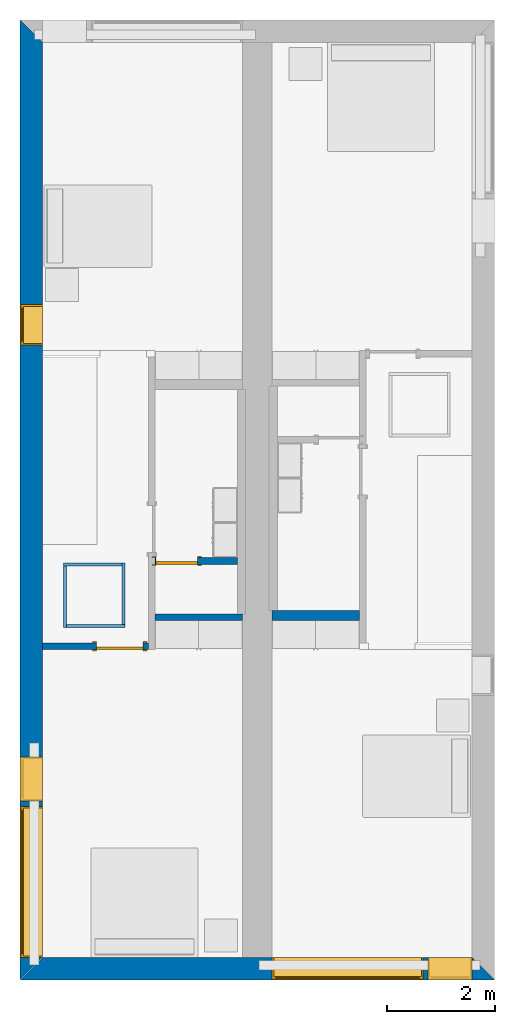
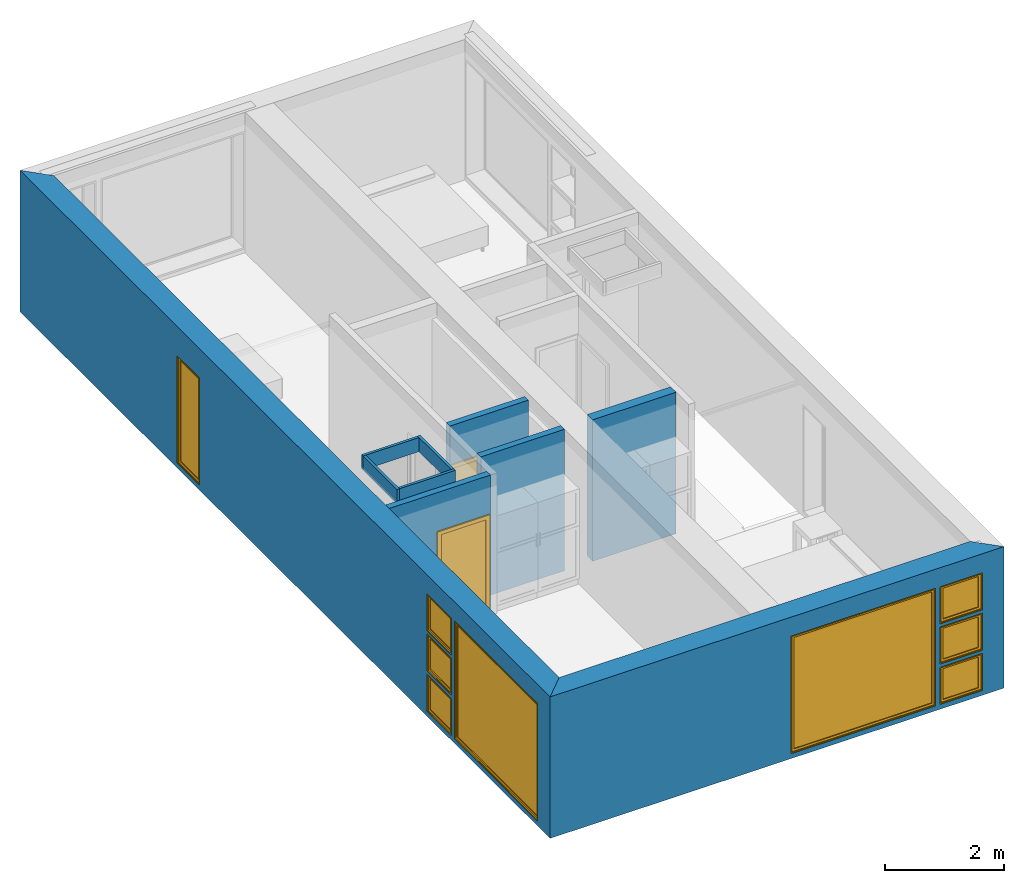
# One storey, part 2 of 14: 10 walls, 9 windows, 2 doors, 11 openings.
"""IFC2X3 building model written with IfcOpenShell, lengths in metres."""

from ifc_helpers import new_model, entity, si_unit, converted_unit, frame, frame_2d, origin, origin_2d_with_axis, place, context, project, spatial, polyline, rectangle, outline, extrude, source, transform, mapped, material, layer, layer_set, layer_usage, type_object, type_shapes, element, fill, save


model = new_model("IFC2X3")

# Units and contexts
model_context = context("Model", 3, precision=1e-09, world=origin())
plan_context = context("Plan", 3, precision=1e-09, world=origin())
ifc_project = project(units=[si_unit("LENGTHUNIT", "METRE"), si_unit("AREAUNIT", "SQUARE_METRE"), si_unit("VOLUMEUNIT", "CUBIC_METRE"), converted_unit("PLANEANGLEUNIT", "DEGREE", entity("IfcRatioMeasure", 0.01745329251994328), si_unit("PLANEANGLEUNIT", "RADIAN"), dimensions=[0, 0, 0, 0, 0, 0, 0]), si_unit("TIMEUNIT", "SECOND")], contexts=[model_context, plan_context])

# Site, building, storey
site_placement = place(None, origin())
site = spatial("IfcSite", under=ifc_project, at=site_placement, CompositionType="ELEMENT")
building_placement = place(site_placement, origin())
building = spatial("IfcBuilding", under=site, at=building_placement, CompositionType="ELEMENT")
storey_placement = place(building_placement, frame((0.0, 0.0, 3.100000000000378)))
storey = spatial("IfcBuildingStorey", under=building, at=storey_placement, Name="Level 2", CompositionType="ELEMENT", Elevation=3.100000000000378)

# Wall, openings, windows
ifc_material_1 = material(Name="Masonry - Brick")
ifc_layer_1 = layer(ifc_material_1, 0.092)
ifc_material_2 = material(Name="Misc. Air Layers - Air Space")
ifc_layer_2 = layer(ifc_material_2, 0.025)
ifc_material_3 = material(Name="Insulation / Thermal Barriers - Rigid insulation")
ifc_layer_3 = layer(ifc_material_3, 0.05)
ifc_material_4 = material(Name="Masonry - Concrete Block")
ifc_layer_4 = layer(ifc_material_4, 0.193)
ifc_material_5 = material(Name="Metal - Stud Layer")
ifc_layer_5 = layer(ifc_material_5, 0.041)
ifc_material_6 = material(Name="Plasterboard")
ifc_layer_6 = layer(ifc_material_6, 0.016)
ifc_layer_set_1 = layer_set([ifc_layer_1, ifc_layer_2, ifc_layer_3, ifc_layer_4, ifc_layer_5, ifc_layer_6], Name="Basic Wall:Exterior - Brick on Block")
ifc_layer_usage_1 = layer_usage(ifc_layer_set_1, "AXIS2", "NEGATIVE", 0.2085000000000001)
wall_1_placement = place(storey_placement, frame((0.208499999999999, -17.79999999999997, 0.0), z_axis=(0.0, 0.0, 1.0), x_axis=(0.0, 1.0, 0.0)))
wall_1 = element("IfcWallStandardCase", 1, at=wall_1_placement, inside=storey, material=ifc_layer_usage_1, Name="Basic Wall:Exterior - Brick on Block", ObjectType="Basic Wall:Exterior - Brick on Block", context=model_context, shape_type="SweptSolid", body=[
    extrude(outline(polyline([(17.38299999999997, -0.2085000000000001), (17.79999999999997, 0.2085000000000001), (0.0, 0.2085000000000001), (0.4170000000000005, -0.2085), (6.125999999999976, -0.2085), (6.249999999999976, -0.2085000000000001), (17.38299999999997, -0.2085000000000001)])), origin(), (0.0, 0.0, 1.0), 2.900000000000013),
])
opening_1_placement = place(wall_1_placement, frame((3.317000000000015, -0.2085000000000003, 0.9254999999998184)))
opening_1 = element("IfcOpeningElement", 2, at=opening_1_placement, cuts=wall_1, ObjectType="Opening", context=model_context, shape_type="SweptSolid", body=[
    extrude(rectangle(XDim=0.7590000000000007, YDim=0.8189999999999998, at=frame_2d((0.3795000000000003, 0.4094999999999999), x_axis=(-1.0, 0.0))), frame((0.0, 0.0, 0.0), z_axis=(0.0, 1.0, 0.0), x_axis=(0.0, 0.0, 1.0)), (0.0, 0.0, 1.0), 0.4170000000000001),
])
opening_2_placement = place(wall_1_placement, frame((11.77399999999997, -0.2084999999999996, 0.09999999999981862)))
opening_2 = element("IfcOpeningElement", 3, at=opening_2_placement, cuts=wall_1, ObjectType="Opening", context=model_context, shape_type="SweptSolid", body=[
    extrude(rectangle(XDim=2.199999999999996, YDim=0.7499999999999996, at=frame_2d((1.099999999999999, 0.3749999999999987), x_axis=(1.0, 0.0))), frame((0.0, 0.0, 0.0), z_axis=(0.0, 1.0, 0.0), x_axis=(0.0, 0.0, 1.0)), (0.0, 0.0, 1.0), 0.4170000000000001),
])
opening_3_placement = place(wall_1_placement, frame((3.317, -0.208499999999999, 0.09999999999981862)))
opening_3 = element("IfcOpeningElement", 4, at=opening_3_placement, cuts=wall_1, ObjectType="Opening", context=model_context, shape_type="SweptSolid", body=[
    extrude(rectangle(XDim=0.7589999999999981, YDim=0.8189999999999995, at=frame_2d((0.3794999999999993, 0.4095000000000003), x_axis=(1.0, 0.0))), frame((0.0, 0.0, 0.0), z_axis=(0.0, 1.0, 0.0), x_axis=(0.0, 0.0, 1.0)), (0.0, 0.0, 1.0), 0.4170000000000001),
])
opening_4_placement = place(wall_1_placement, frame((0.4169999999999983, -0.2084999999999956, 0.09999999999981862)))
opening_4 = element("IfcOpeningElement", 5, at=opening_4_placement, cuts=wall_1, ObjectType="Opening", context=model_context, shape_type="SweptSolid", body=[
    extrude(rectangle(XDim=2.409999999999996, YDim=2.8, at=frame_2d((1.204999999999998, 1.4), x_axis=(1.0, 0.0))), frame((0.0, 0.0, 0.0), z_axis=(0.0, 1.0, 0.0), x_axis=(0.0, 0.0, 1.0)), (0.0, 0.0, 1.0), 0.4170000000000001),
])
opening_5_placement = place(wall_1_placement, frame((3.317, -0.208499999999999, 1.750999999999819)))
opening_5 = element("IfcOpeningElement", 6, at=opening_5_placement, cuts=wall_1, ObjectType="Opening", context=model_context, shape_type="SweptSolid", body=[
    extrude(rectangle(XDim=0.7589999999999981, YDim=0.8189999999999995, at=frame_2d((0.379499999999999, 0.4095000000000003), x_axis=(1.0, 0.0))), frame((0.0, 0.0, 0.0), z_axis=(0.0, 1.0, 0.0), x_axis=(0.0, 0.0, 1.0)), (0.0, 0.0, 1.0), 0.4170000000000001),
])
window_style_1 = type_object("IfcWindowStyle", Name="819mm x 759mm", ConstructionType="NOTDEFINED", OperationType="NOTDEFINED", ParameterTakesPrecedence=False, Sizeable=False)
shared_shape_1 = source(origin(), model_context, "Body", "SweptSolid", [
    extrude(rectangle(XDim=0.01199999999999998, YDim=0.6929999999999971, at=origin_2d_with_axis()), frame((0.4095000000000068, 0.3759999999999988, 0.06299999999998514), z_axis=(0.0, 0.0, 1.0), x_axis=(0.0, -1.0, 0.0)), (0.0, 0.0, 1.0), 0.6330000000000073),
    extrude(outline(polyline([(-0.3904999999999999, -0.3605000000000028), (0.3904999999999999, -0.3605000000000028), (0.3904999999999999, 0.3605000000000027), (-0.3904999999999999, 0.3605000000000027), (-0.3904999999999999, -0.3605000000000028)]), holes=[polyline([(-0.3464999999999996, -0.3165000000000033), (-0.3464999999999996, 0.316500000000004), (0.3464999999999974, 0.316500000000004), (0.3464999999999974, -0.3165000000000033), (-0.3464999999999996, -0.3165000000000033)])]), frame((0.4095000000000078, 0.3539999999999714, 0.3794999999999891), z_axis=(0.0, 1.0, 0.0), x_axis=(1.0, 0.0, 0.0)), (0.0, 0.0, 1.0), 0.04400000000002743),
    extrude(outline(polyline([(-0.4094999999999998, -0.3794999999999972), (0.4094999999999998, -0.3794999999999972), (0.4094999999999998, 0.3794999999999971), (-0.4094999999999998, 0.3794999999999971), (-0.4094999999999998, -0.3794999999999972)]), holes=[polyline([(-0.3905000000000011, -0.3604999999999823), (-0.3905000000000012, 0.3605000000000231), (0.3904999999999986, 0.3605000000000231), (0.3904999999999987, -0.3604999999999823), (-0.3905000000000011, -0.3604999999999823)])]), frame((0.4095000000000091, 0.3539999999999714, 0.3795000000000096), z_axis=(0.0, 1.0, 0.0), x_axis=(1.0, 0.0, 0.0)), (0.0, 0.0, 1.0), 0.06300000000002744),
    extrude(outline(polyline([(-0.4095000000000002, -0.3794999999999967), (0.4095000000000002, -0.3794999999999967), (0.4095000000000002, 0.3794999999999966), (-0.4095000000000002, 0.3794999999999966), (-0.4095000000000002, -0.3794999999999967)]), holes=[polyline([(-0.3774999999999999, -0.3474999999999832), (-0.3774999999999999, 0.3475000000000212), (0.3775000000000001, 0.3475000000000212), (0.3775000000000001, -0.3474999999999832), (-0.3774999999999999, -0.3474999999999832)])]), frame((0.4095000000000096, 0.0, 0.379500000000009), z_axis=(0.0, 1.0, 0.0), x_axis=(1.0, 0.0, 0.0)), (0.0, 0.0, 1.0), 0.3539999999999727),
])
type_shapes(window_style_1, [shared_shape_1])
window_1_placement = place(opening_3_placement, origin())
window_1 = element("IfcWindow", 7, at=window_1_placement, inside=storey, type_object=window_style_1, ObjectType="819mm x 759mm", OverallHeight=0.7589999999999986, OverallWidth=0.8190000000000001, context=model_context, shape_type="MappedRepresentation", body=[
    mapped(shared_shape_1, transform((0.0, 0.0, 0.0), scale=1.0)),
])
fill(opening_3, window_1)
window_2_placement = place(opening_5_placement, origin())
window_2 = element("IfcWindow", 8, at=window_2_placement, inside=storey, type_object=window_style_1, ObjectType="819mm x 759mm", OverallHeight=0.758999999999998, OverallWidth=0.8190000000000001, context=model_context, shape_type="MappedRepresentation", body=[
    mapped(shared_shape_1, transform((0.0, 0.0, 0.0), scale=1.0)),
])
fill(opening_5, window_2)
window_style_2 = type_object("IfcWindowStyle", Name="2800mm x 2410mm", ConstructionType="NOTDEFINED", OperationType="NOTDEFINED", ParameterTakesPrecedence=False, Sizeable=False)
shared_shape_2 = source(origin(), model_context, "Body", "SweptSolid", [
    extrude(rectangle(XDim=0.01199999999999998, YDim=2.673999999999997, at=origin_2d_with_axis()), frame((1.400000000000007, 0.3759999999999956, 0.06299999999998514), z_axis=(0.0, 0.0, 1.0), x_axis=(0.0, -1.0, 0.0)), (0.0, 0.0, 1.0), 2.284000000000005),
    extrude(outline(polyline([(-1.381, -1.186000000000001), (1.381, -1.186000000000001), (1.381, 1.186000000000001), (-1.381, 1.186000000000001), (-1.381, -1.186000000000001)]), holes=[polyline([(-1.336999999999999, -1.142000000000002), (-1.336999999999999, 1.142000000000003), (1.336999999999997, 1.142000000000003), (1.336999999999997, -1.142000000000002), (-1.336999999999999, -1.142000000000002)])]), frame((1.400000000000008, 0.3539999999999681, 1.204999999999988), z_axis=(0.0, 1.0, 0.0), x_axis=(1.0, 0.0, 0.0)), (0.0, 0.0, 1.0), 0.04400000000002743),
    extrude(outline(polyline([(-1.4, -1.204999999999996), (1.4, -1.204999999999996), (1.4, 1.204999999999996), (-1.4, 1.204999999999996), (-1.4, -1.204999999999996)]), holes=[polyline([(-1.381000000000001, -1.185999999999981), (-1.381000000000001, 1.186000000000022), (1.380999999999999, 1.186000000000022), (1.380999999999999, -1.185999999999981), (-1.381000000000001, -1.185999999999981)])]), frame((1.400000000000009, 0.3539999999999681, 1.205000000000009), z_axis=(0.0, 1.0, 0.0), x_axis=(1.0, 0.0, 0.0)), (0.0, 0.0, 1.0), 0.06300000000002744),
    extrude(outline(polyline([(-1.4, -1.204999999999995), (1.4, -1.204999999999995), (1.4, 1.204999999999995), (-1.4, 1.204999999999995), (-1.4, -1.204999999999995)]), holes=[polyline([(-1.368, -1.172999999999982), (-1.368, 1.17300000000002), (1.368, 1.17300000000002), (1.367999999999999, -1.172999999999982), (-1.368, -1.172999999999982)])]), frame((1.40000000000001, 0.0, 1.205000000000008), z_axis=(0.0, 1.0, 0.0), x_axis=(1.0, 0.0, 0.0)), (0.0, 0.0, 1.0), 0.3539999999999727),
])
type_shapes(window_style_2, [shared_shape_2])
window_3_placement = place(opening_4_placement, origin())
window_3 = element("IfcWindow", 9, at=window_3_placement, inside=storey, type_object=window_style_2, ObjectType="2800mm x 2410mm", OverallHeight=2.409999999999996, OverallWidth=2.8, context=model_context, shape_type="MappedRepresentation", body=[
    mapped(shared_shape_2, transform((0.0, 0.0, 0.0), scale=1.0)),
])
fill(opening_4, window_3)
window_style_3 = type_object("IfcWindowStyle", Name="750mm x 2200mm", ConstructionType="NOTDEFINED", OperationType="NOTDEFINED", ParameterTakesPrecedence=False, Sizeable=False)
shared_shape_3 = source(origin(), model_context, "Body", "SweptSolid", [
    extrude(rectangle(XDim=0.01199999999999998, YDim=0.623999999999997, at=origin_2d_with_axis()), frame((0.375000000000007, 0.3759999999999988, 0.06299999999998514), z_axis=(0.0, 0.0, 1.0), x_axis=(0.0, -1.0, 0.0)), (0.0, 0.0, 1.0), 2.074000000000006),
    extrude(outline(polyline([(-0.3559999999999999, -1.081000000000002), (0.3559999999999999, -1.081000000000002), (0.3559999999999999, 1.081000000000002), (-0.3559999999999999, 1.081000000000002), (-0.3559999999999999, -1.081000000000002)]), holes=[polyline([(-0.3119999999999996, -1.037000000000002), (-0.3119999999999996, 1.037000000000003), (0.3119999999999975, 1.037000000000003), (0.3119999999999975, -1.037000000000002), (-0.3119999999999996, -1.037000000000002)])]), frame((0.3750000000000081, 0.3539999999999715, 1.099999999999989), z_axis=(0.0, 1.0, 0.0), x_axis=(1.0, 0.0, 0.0)), (0.0, 0.0, 1.0), 0.04400000000002743),
    extrude(outline(polyline([(-0.3749999999999997, -1.099999999999996), (0.3749999999999997, -1.099999999999996), (0.3749999999999997, 1.099999999999996), (-0.3749999999999997, 1.099999999999996), (-0.3749999999999997, -1.099999999999996)]), holes=[polyline([(-0.3560000000000012, -1.080999999999981), (-0.3560000000000013, 1.081000000000022), (0.3559999999999985, 1.081000000000022), (0.3559999999999986, -1.080999999999981), (-0.3560000000000012, -1.080999999999981)])]), frame((0.3750000000000094, 0.3539999999999715, 1.100000000000009), z_axis=(0.0, 1.0, 0.0), x_axis=(1.0, 0.0, 0.0)), (0.0, 0.0, 1.0), 0.06300000000002744),
    extrude(outline(polyline([(-0.3750000000000001, -1.099999999999996), (0.3750000000000001, -1.099999999999996), (0.3750000000000001, 1.099999999999996), (-0.3750000000000001, 1.099999999999996), (-0.3750000000000001, -1.099999999999996)]), holes=[polyline([(-0.3429999999999999, -1.067999999999982), (-0.3429999999999999, 1.06800000000002), (0.3430000000000001, 1.06800000000002), (0.3430000000000001, -1.067999999999982), (-0.3429999999999999, -1.067999999999982)])]), frame((0.3750000000000099, 0.0, 1.100000000000008), z_axis=(0.0, 1.0, 0.0), x_axis=(1.0, 0.0, 0.0)), (0.0, 0.0, 1.0), 0.3539999999999727),
])
type_shapes(window_style_3, [shared_shape_3])
window_4_placement = place(opening_2_placement, origin())
window_4 = element("IfcWindow", 10, at=window_4_placement, inside=storey, type_object=window_style_3, ObjectType="750mm x 2200mm", OverallHeight=2.199999999999997, OverallWidth=0.7499999999999996, context=model_context, shape_type="MappedRepresentation", body=[
    mapped(shared_shape_3, transform((0.0, 0.0, 0.0), scale=1.0)),
])
fill(opening_2, window_4)
window_style_4 = type_object("IfcWindowStyle", Name="819mm x 759mm", ConstructionType="NOTDEFINED", OperationType="NOTDEFINED", ParameterTakesPrecedence=False, Sizeable=False)
shared_shape_4 = source(origin(), model_context, "Body", "SweptSolid", [
    extrude(rectangle(XDim=0.01269999999999999, YDim=0.6919999999999978, at=origin_2d_with_axis()), frame((0.4095000000000003, 0.3757750000000001, 0.06350000000000397), z_axis=(0.0, 0.0, 1.0), x_axis=(0.0, 1.0, 0.0)), (0.0, 0.0, 1.0), 0.6320000000000041),
    extrude(outline(polyline([(-0.3904499999999989, -0.3604500000000012), (0.3904499999999989, -0.3604500000000012), (0.3904499999999989, 0.3604500000000012), (-0.3904499999999989, 0.3604500000000012), (-0.3904499999999989, -0.3604500000000012)]), holes=[polyline([(-0.3459999999999978, -0.3160000000000016), (-0.3459999999999978, 0.3160000000000026), (0.346, 0.3160000000000026), (0.346, -0.3160000000000016), (-0.3459999999999978, -0.3160000000000016)])]), frame((0.4094999999999992, 0.3535500000000001, 0.3795000000000066), z_axis=(0.0, 1.0, 0.0), x_axis=(1.0, 0.0, 0.0)), (0.0, 0.0, 1.0), 0.04445),
    extrude(outline(polyline([(-0.4094999999999992, -0.3795000000000012), (0.4094999999999992, -0.3795000000000012), (0.4094999999999992, 0.3795000000000012), (-0.4094999999999992, 0.3795000000000012), (-0.4094999999999992, -0.3795000000000012)]), holes=[polyline([(-0.3777500000000001, -0.3477499999999997), (-0.3777500000000001, 0.3477500000000008), (0.3777499999999982, 0.3477500000000008), (0.3777499999999982, -0.3477499999999997), (-0.3777500000000001, -0.3477499999999997)])]), frame((0.4095000000000007, 0.0, 0.3795000000000077), z_axis=(0.0, 1.0, 0.0), x_axis=(1.0, 0.0, 0.0)), (0.0, 0.0, 1.0), 0.3535500000000001),
    extrude(outline(polyline([(-0.3795000000000017, -0.4094999999999995), (0.3795000000000017, -0.4094999999999995), (0.3795000000000017, 0.4094999999999995), (-0.3795000000000017, 0.4094999999999995), (-0.3795000000000017, -0.4094999999999995)]), holes=[polyline([(-0.3604500000000023, -0.3904499999999987), (-0.3604500000000023, 0.3904499999999997), (0.3604500000000017, 0.3904499999999997), (0.3604500000000017, -0.3904499999999988), (-0.3604500000000023, -0.3904499999999987)])]), frame((0.4095000000000004, 0.3535500000000001, 0.3795000000000071), z_axis=(0.0, 1.0, 0.0), x_axis=(0.0, 0.0, -1.0)), (0.0, 0.0, 1.0), 0.06345),
])
type_shapes(window_style_4, [shared_shape_4])
window_5_placement = place(opening_1_placement, origin())
window_5 = element("IfcWindow", 11, at=window_5_placement, inside=storey, type_object=window_style_4, ObjectType="819mm x 759mm", OverallHeight=0.7590000000000007, OverallWidth=0.8190000000000001, context=model_context, shape_type="MappedRepresentation", body=[
    mapped(shared_shape_4, transform((0.0, 0.0, 0.0), scale=1.0)),
])
fill(opening_1, window_5)

wall_2_placement = place(storey_placement, frame((8.799999999999974, -17.5915, 0.0), z_axis=(0.0, 0.0, 1.0), x_axis=(-1.0, 0.0, 0.0)))
wall_2 = element("IfcWallStandardCase", 12, at=wall_2_placement, inside=storey, material=ifc_layer_usage_1, Name="Basic Wall:Exterior - Brick on Block", ObjectType="Basic Wall:Exterior - Brick on Block", context=model_context, shape_type="SweptSolid", body=[
    extrude(outline(polyline([(8.382999999999974, -0.2084999999999994), (8.799999999999974, 0.2085000000000002), (0.0, 0.2085000000000002), (0.4170000000000034, -0.2085000000000011), (4.125000000000003, -0.2085000000000001), (4.675000000000003, -0.2085000000000005), (8.382999999999974, -0.2084999999999994)])), origin(), (0.0, 0.0, 1.0), 2.900000000000012),
])
opening_6_placement = place(wall_2_placement, frame((0.4170000000000005, -0.2084999999999993, 1.750999999999819)))
opening_6 = element("IfcOpeningElement", 13, at=opening_6_placement, cuts=wall_2, ObjectType="Opening", context=model_context, shape_type="SweptSolid", body=[
    extrude(rectangle(XDim=0.7589999999999981, YDim=0.8189999999999995, at=frame_2d((0.379499999999999, 0.4095000000000003), x_axis=(1.0, 0.0))), frame((0.0, 0.0, 0.0), z_axis=(0.0, 1.0, 0.0), x_axis=(0.0, 0.0, 1.0)), (0.0, 0.0, 1.0), 0.4170000000000001),
])
opening_7_placement = place(wall_2_placement, frame((1.325000000000001, -0.2084999999999981, 0.09999999999982295)))
opening_7 = element("IfcOpeningElement", 14, at=opening_7_placement, cuts=wall_2, ObjectType="Opening", context=model_context, shape_type="SweptSolid", body=[
    extrude(rectangle(XDim=2.409999999999996, YDim=2.8, at=frame_2d((1.204999999999998, 1.4), x_axis=(1.0, 0.0))), frame((0.0, 0.0, 0.0), z_axis=(0.0, 1.0, 0.0), x_axis=(0.0, 0.0, 1.0)), (0.0, 0.0, 1.0), 0.4170000000000001),
])
opening_8_placement = place(wall_2_placement, frame((0.4170000000000168, -0.2084999999999998, 0.9254999999998184)))
opening_8 = element("IfcOpeningElement", 15, at=opening_8_placement, cuts=wall_2, ObjectType="Opening", context=model_context, shape_type="SweptSolid", body=[
    extrude(rectangle(XDim=0.7590000000000007, YDim=0.8189999999999998, at=frame_2d((0.3795000000000003, 0.4094999999999999), x_axis=(-1.0, 0.0))), frame((0.0, 0.0, 0.0), z_axis=(0.0, 1.0, 0.0), x_axis=(0.0, 0.0, 1.0)), (0.0, 0.0, 1.0), 0.4170000000000001),
])
opening_9_placement = place(wall_2_placement, frame((0.4170000000000005, -0.2084999999999993, 0.0999999999998235)))
opening_9 = element("IfcOpeningElement", 16, at=opening_9_placement, cuts=wall_2, ObjectType="Opening", context=model_context, shape_type="SweptSolid", body=[
    extrude(rectangle(XDim=0.7589999999999981, YDim=0.8189999999999995, at=frame_2d((0.379499999999999, 0.4095000000000003), x_axis=(1.0, 0.0))), frame((0.0, 0.0, 0.0), z_axis=(0.0, 1.0, 0.0), x_axis=(0.0, 0.0, 1.0)), (0.0, 0.0, 1.0), 0.4170000000000001),
])
window_6_placement = place(opening_9_placement, origin())
window_6 = element("IfcWindow", 17, at=window_6_placement, inside=storey, type_object=window_style_1, ObjectType="819mm x 759mm", OverallHeight=0.758999999999998, OverallWidth=0.8190000000000001, context=model_context, shape_type="MappedRepresentation", body=[
    mapped(shared_shape_1, transform((0.0, 0.0, 0.0), scale=1.0)),
])
fill(opening_9, window_6)
window_7_placement = place(opening_6_placement, origin())
window_7 = element("IfcWindow", 18, at=window_7_placement, inside=storey, type_object=window_style_1, ObjectType="819mm x 759mm", OverallHeight=0.758999999999998, OverallWidth=0.8190000000000001, context=model_context, shape_type="MappedRepresentation", body=[
    mapped(shared_shape_1, transform((0.0, 0.0, 0.0), scale=1.0)),
])
fill(opening_6, window_7)
window_8_placement = place(opening_7_placement, origin())
window_8 = element("IfcWindow", 19, at=window_8_placement, inside=storey, type_object=window_style_2, ObjectType="2800mm x 2410mm", OverallHeight=2.409999999999996, OverallWidth=2.8, context=model_context, shape_type="MappedRepresentation", body=[
    mapped(shared_shape_2, transform((0.0, 0.0, 0.0), scale=1.0)),
])
fill(opening_7, window_8)
window_9_placement = place(opening_8_placement, origin())
window_9 = element("IfcWindow", 20, at=window_9_placement, inside=storey, type_object=window_style_4, ObjectType="819mm x 759mm", OverallHeight=0.7590000000000007, OverallWidth=0.8190000000000001, context=model_context, shape_type="MappedRepresentation", body=[
    mapped(shared_shape_4, transform((0.0, 0.0, 0.0), scale=1.0)),
])
fill(opening_8, window_9)

# Walls
ifc_layer_7 = layer(ifc_material_6, 0.016)
ifc_layer_8 = layer(ifc_material_5, 0.152)
ifc_layer_9 = layer(ifc_material_6, 0.016)
ifc_layer_set_2 = layer_set([ifc_layer_7, ifc_layer_8, ifc_layer_9], Name="Basic Wall:Interior - Plumbing (152mm Stud)")
ifc_layer_usage_2 = layer_usage(ifc_layer_set_2, "AXIS2", "NEGATIVE", 0.092)
wall_3_placement = place(storey_placement, frame((6.294000000000001, -11.04200000000001, 0.0), z_axis=(0.0, 0.0, 1.0), x_axis=(-1.0, 0.0, 0.0)))
element("IfcWallStandardCase", 21, at=wall_3_placement, inside=storey, material=ifc_layer_usage_2, Name="Basic Wall:Interior - Plumbing (152mm Stud)", ObjectType="Basic Wall:Interior - Plumbing (152mm Stud)", context=model_context, shape_type="SweptSolid", body=[
    extrude(rectangle(XDim=1.619000000000018, YDim=0.1840000000000015, at=frame_2d((0.8095000000000092, 0.0), x_axis=(-1.0, 0.0))), origin(), (0.0, 0.0, 1.0), 2.900000000000012),
])
ifc_layer_10 = layer(ifc_material_6, 0.016)
ifc_layer_11 = layer(ifc_material_5, 0.092)
ifc_layer_12 = layer(ifc_material_6, 0.016)
ifc_layer_set_3 = layer_set([ifc_layer_10, ifc_layer_11, ifc_layer_12], Name="Basic Wall:Interior - Partition (92mm Stud)")
ifc_layer_usage_3 = layer_usage(ifc_layer_set_3, "AXIS2", "NEGATIVE", 0.062)
wall_4_placement = place(storey_placement, frame((4.124999999999983, -11.072, 0.0), z_axis=(0.0, 0.0, 1.0), x_axis=(-1.0, 0.0, 0.0)))
element("IfcWallStandardCase", 22, at=wall_4_placement, inside=storey, material=ifc_layer_usage_3, Name="Basic Wall:Interior - Partition (92mm Stud)", ObjectType="Basic Wall:Interior - Partition (92mm Stud)", context=model_context, shape_type="SweptSolid", body=[
    extrude(rectangle(XDim=1.61899999999999, YDim=0.1240000000000021, at=frame_2d((0.8094999999999952, 0.0), x_axis=(-1.0, 0.0))), origin(), (0.0, 0.0, 1.0), 2.900000000000012),
])

# Wall, opening, door
wall_5_placement = place(storey_placement, frame((2.381999999999991, -11.612, 0.0), z_axis=(0.0, 0.0, 1.0), x_axis=(-1.0, 0.0, 0.0)))
wall_5 = element("IfcWallStandardCase", 23, at=wall_5_placement, inside=storey, material=ifc_layer_usage_3, Name="Basic Wall:Interior - Partition (92mm Stud)", ObjectType="Basic Wall:Interior - Partition (92mm Stud)", context=model_context, shape_type="SweptSolid", body=[
    extrude(rectangle(XDim=1.964999999999992, YDim=0.1240000000000021, at=frame_2d((0.9824999999999962, 0.0), x_axis=(-1.0, 0.0))), origin(), (0.0, 0.0, 1.0), 2.900000000000012),
])
opening_10_placement = place(wall_5_placement, frame((0.09999999999999892, -0.0620000000000021, 0.0)))
opening_10 = element("IfcOpeningElement", 24, at=opening_10_placement, cuts=wall_5, Name="M_Single-Flush:0864 x 2032mm:0864 x 2032mm:1", ObjectType="Opening", context=model_context, shape_type="SweptSolid", body=[
    extrude(rectangle(XDim=0.8639999999999994, YDim=2.032, at=frame_2d((1.016, 0.4319999999999998), x_axis=(0.0, -1.0))), frame((0.0, 0.0, 0.0), z_axis=(0.0, 1.0, 0.0), x_axis=(0.0, 0.0, 1.0)), (0.0, 0.0, 1.0), 0.124),
])
door_style_1 = type_object("IfcDoorStyle", Name="0864 x 2032mm", ConstructionType="NOTDEFINED", OperationType="SINGLE_SWING_LEFT", ParameterTakesPrecedence=False, Sizeable=False)
shared_shape_5 = source(origin(), model_context, "Body", "SweptSolid", [
    extrude(outline(polyline([(-0.5079999999999999, -1.072999999999999), (0.5079999999999998, -1.072999999999999), (0.5079999999999998, 1.035000000000001), (0.4319999999999997, 1.035000000000001), (0.4319999999999997, -0.9970000000000019), (-0.4319999999999996, -0.9970000000000019), (-0.4319999999999996, 1.035000000000001), (-0.5079999999999999, 1.035000000000001), (-0.5079999999999999, -1.072999999999999)])), frame((0.4320000000000002, 0.1489999999999882, 1.035000000000001), z_axis=(0.0, -1.0, 0.0), x_axis=(-1.0, 0.0, 0.0)), (0.0, 0.0, 1.0), 0.02499999999999444),
    extrude(outline(polyline([(-1.073, -0.5079999999999971), (1.035, -0.5079999999999971), (1.035, -0.4320000000000073), (-0.9969999999999997, -0.4320000000000073), (-0.9969999999999997, 0.4320000000000018), (1.035, 0.4320000000000018), (1.035, 0.5080000000000027), (-1.073, 0.5080000000000027), (-1.073, -0.5079999999999971)])), frame((0.4319999999999979, 0.0, 1.035), z_axis=(0.0, -1.0, 0.0), x_axis=(0.0, 0.0, -1.0)), (0.0, 0.0, 1.0), 0.02500000000000558),
    extrude(rectangle(XDim=0.8639999999999998, YDim=0.051, at=origin_2d_with_axis()), frame((0.4320000000000005, 0.09849999999999375, 0.0)), (0.0, 0.0, 1.0), 2.032),
])
type_shapes(door_style_1, [shared_shape_5])
door_1_placement = place(opening_10_placement, origin())
door_1 = element("IfcDoor", 25, at=door_1_placement, inside=storey, type_object=door_style_1, Name="M_Single-Flush:0864 x 2032mm:0864 x 2032mm", ObjectType="0864 x 2032mm", OverallHeight=2.032, OverallWidth=0.8639999999999995, context=model_context, shape_type="MappedRepresentation", body=[
    mapped(shared_shape_5, transform((0.0, 0.0, 0.0), scale=1.0)),
])
fill(opening_10, door_1)

wall_6_placement = place(storey_placement, frame((4.029999999999983, -10.03205117851059, 0.0), z_axis=(0.0, 0.0, 1.0), x_axis=(-1.0, 0.0, 0.0)))
wall_6 = element("IfcWallStandardCase", 26, at=wall_6_placement, inside=storey, material=ifc_layer_usage_3, Name="Basic Wall:Interior - Partition (92mm Stud)", ObjectType="Basic Wall:Interior - Partition (92mm Stud)", context=model_context, shape_type="SweptSolid", body=[
    extrude(rectangle(XDim=1.52399999999999, YDim=0.1240000000000021, at=frame_2d((0.7619999999999951, 0.0), x_axis=(-1.0, 0.0))), origin(), (0.0, 0.0, 1.0), 2.900000000000012),
])
opening_11_placement = place(wall_6_placement, frame((0.7419999999999857, -0.0619999999999989, 0.0)))
opening_11 = element("IfcOpeningElement", 27, at=opening_11_placement, cuts=wall_6, Name="M_Single-Flush:0762 x 2032mm:0762 x 2032mm:1", ObjectType="Opening", context=model_context, shape_type="SweptSolid", body=[
    extrude(rectangle(XDim=0.7619999999999997, YDim=2.032, at=frame_2d((1.016, 0.3810000000000001), x_axis=(0.0, 1.0))), frame((0.0, 0.0, 0.0), z_axis=(0.0, 1.0, 0.0), x_axis=(0.0, 0.0, 1.0)), (0.0, 0.0, 1.0), 0.124),
])
door_style_2 = type_object("IfcDoorStyle", Name="0762 x 2032mm", ConstructionType="NOTDEFINED", OperationType="SINGLE_SWING_RIGHT", ParameterTakesPrecedence=False, Sizeable=False)
shared_shape_6 = source(origin(), model_context, "Body", "SweptSolid", [
    extrude(outline(polyline([(-0.457, -1.072999999999999), (0.4569999999999999, -1.072999999999999), (0.4569999999999999, 1.035000000000001), (0.3809999999999998, 1.035000000000001), (0.3809999999999998, -0.9970000000000019), (-0.3809999999999997, -0.9970000000000019), (-0.3809999999999997, 1.035000000000001), (-0.457, 1.035000000000001), (-0.457, -1.072999999999999)])), frame((0.3810000000000009, 0.1239999999999993, 1.035000000000001), z_axis=(0.0, 1.0, 0.0), x_axis=(1.0, 0.0, 0.0)), (0.0, 0.0, 1.0), 0.02499999999999445),
    extrude(outline(polyline([(-1.073, -0.4569999999999971), (1.035, -0.4569999999999971), (1.035, -0.3810000000000074), (-0.9969999999999997, -0.3810000000000074), (-0.9969999999999997, 0.3810000000000018), (1.035, 0.3810000000000018), (1.035, 0.4570000000000027), (-1.073, 0.4570000000000027), (-1.073, -0.4569999999999971)])), frame((0.3810000000000031, -0.02500000000000627, 1.035), z_axis=(0.0, 1.0, 0.0), x_axis=(0.0, 0.0, -1.0)), (0.0, 0.0, 1.0), 0.02500000000000558),
    extrude(rectangle(XDim=0.051, YDim=0.7619999999999998, at=origin_2d_with_axis()), frame((0.3810000000000005, 0.09849999999999928, 0.0), z_axis=(0.0, 0.0, 1.0), x_axis=(0.0, 1.0, 0.0)), (0.0, 0.0, 1.0), 2.032),
])
type_shapes(door_style_2, [shared_shape_6])
door_2_placement = place(opening_11_placement, origin())
door_2 = element("IfcDoor", 28, at=door_2_placement, inside=storey, type_object=door_style_2, Name="M_Single-Flush:0762 x 2032mm:0762 x 2032mm", ObjectType="0762 x 2032mm", OverallHeight=2.032, OverallWidth=0.762, context=model_context, shape_type="MappedRepresentation", body=[
    mapped(shared_shape_6, transform((0.0, 0.0, 0.0), scale=1.0)),
])
fill(opening_11, door_2)

# Walls
ifc_layer_13 = layer(ifc_material_5, 0.038)
ifc_layer_14 = layer(ifc_material_6, 0.016)
ifc_layer_set_4 = layer_set([ifc_layer_13, ifc_layer_14], Name="Basic Wall:Interior - Furring (38 mm Stud)")
ifc_layer_usage_4 = layer_usage(ifc_layer_set_4, "AXIS2", "NEGATIVE", 0.027)
wall_7_placement = place(storey_placement, frame((0.8344500000000258, -11.25955, 2.612), z_axis=(0.0, 0.0, 1.0), x_axis=(0.0, 1.0, 0.0)))
element("IfcWallStandardCase", 29, at=wall_7_placement, inside=storey, material=ifc_layer_usage_4, Name="Basic Wall:Interior - Furring (38 mm Stud)", ObjectType="Basic Wall:Interior - Furring (38 mm Stud)", context=model_context, shape_type="SweptSolid", body=[
    extrude(rectangle(XDim=1.135099999999957, YDim=0.05399999999999991, at=frame_2d((0.5675499999999782, 0.0), x_axis=(-1.0, 0.0))), origin(), (0.0, 0.0, 1.0), 0.2880000000000125),
])
wall_8_placement = place(storey_placement, frame((1.917550000000025, -10.07045000000004, 2.612), z_axis=(0.0, 0.0, 1.0), x_axis=(0.0, -1.0, 0.0)))
element("IfcWallStandardCase", 30, at=wall_8_placement, inside=storey, material=ifc_layer_usage_4, Name="Basic Wall:Interior - Furring (38 mm Stud)", ObjectType="Basic Wall:Interior - Furring (38 mm Stud)", context=model_context, shape_type="SweptSolid", body=[
    extrude(rectangle(XDim=1.135099999999959, YDim=0.05400000000000018, at=frame_2d((0.5675499999999792, 0.0), x_axis=(-1.0, 0.0))), origin(), (0.0, 0.0, 1.0), 0.2880000000000125),
])
wall_9_placement = place(storey_placement, frame((1.944550000000026, -11.23255, 2.612), z_axis=(0.0, 0.0, 1.0), x_axis=(-1.0, 0.0, 0.0)))
element("IfcWallStandardCase", 31, at=wall_9_placement, inside=storey, material=ifc_layer_usage_4, Name="Basic Wall:Interior - Furring (38 mm Stud)", ObjectType="Basic Wall:Interior - Furring (38 mm Stud)", context=model_context, shape_type="SweptSolid", body=[
    extrude(rectangle(XDim=1.0831, YDim=0.05400000000000071, at=frame_2d((0.5415499999999998, 0.0), x_axis=(-1.0, 0.0))), origin(), (0.0, 0.0, 1.0), 0.2880000000000125),
])
wall_10_placement = place(storey_placement, frame((0.8074500000000259, -10.09745000000004, 2.612)))
element("IfcWallStandardCase", 32, at=wall_10_placement, inside=storey, material=ifc_layer_usage_4, Name="Basic Wall:Interior - Furring (38 mm Stud)", ObjectType="Basic Wall:Interior - Furring (38 mm Stud)", context=model_context, shape_type="SweptSolid", body=[
    extrude(rectangle(XDim=1.0831, YDim=0.05400000000000072, at=frame_2d((0.5415499999999999, 0.0), x_axis=(-1.0, 0.0))), origin(), (0.0, 0.0, 1.0), 0.2880000000000125),
])

save(model, "model.ifc")
